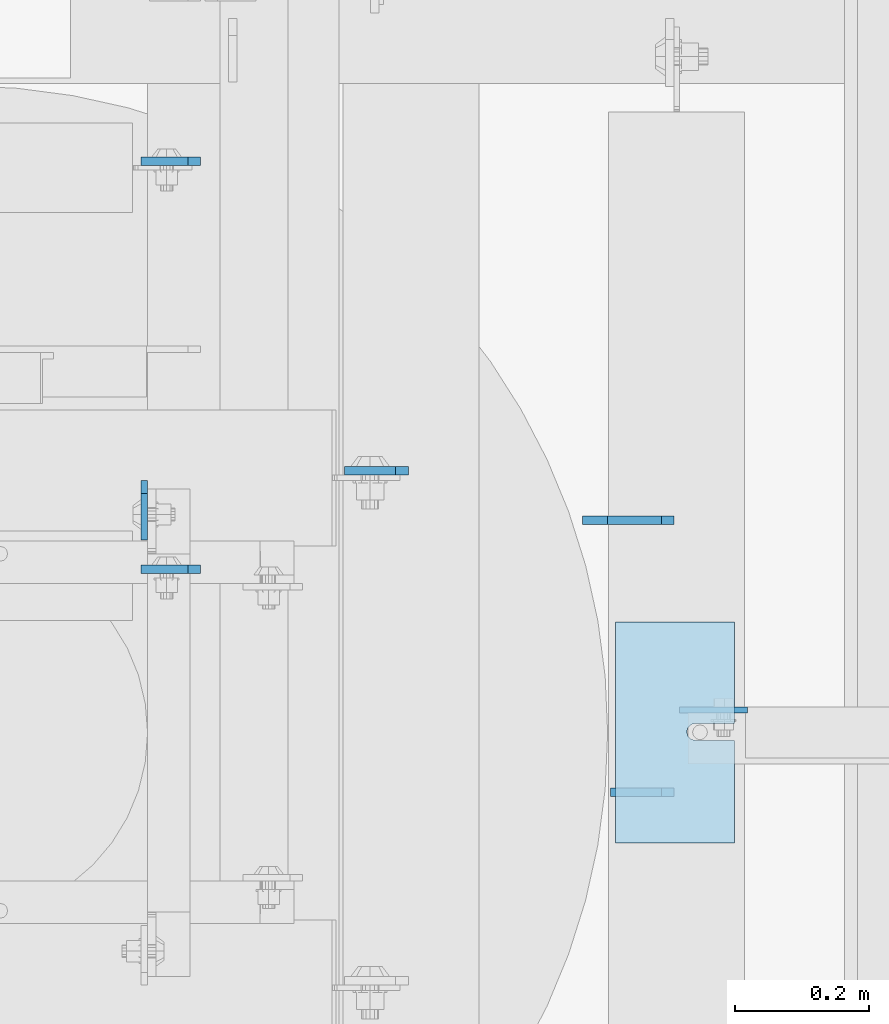
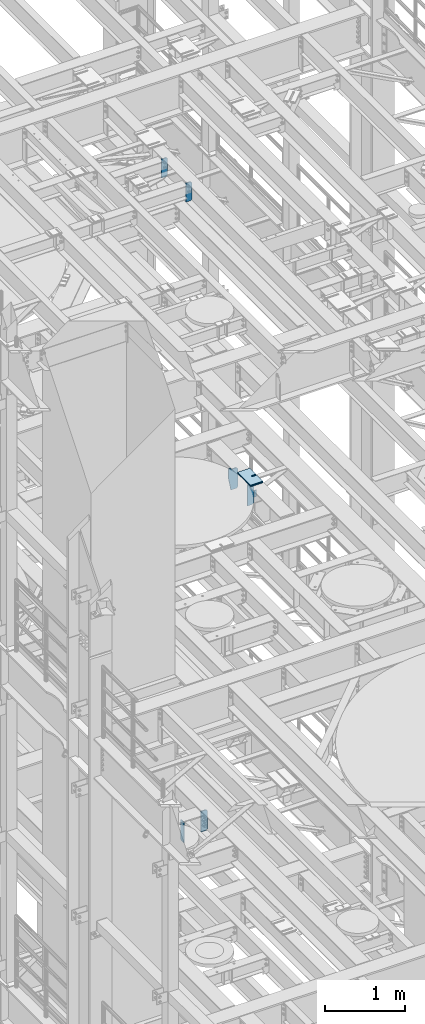
# One storey, part 1655 of 1876: 13 plates, 10 elements without a shape of their own.
"""IFC2X3 building model written with IfcOpenShell, lengths in millimetres."""

from ifc_helpers import new_model, si_unit, frame, origin_with_axes, place, context, subcontext, project, spatial, faceted_brep, material, type_object, element, aggregate, save


model = new_model("IFC2X3")

# Units and contexts
model_context = context("Model", 3, precision=1e-05, world=origin_with_axes())
body_context = subcontext(model_context, "Body", "Model", "MODEL_VIEW")
ifc_project = project(units=[si_unit("LENGTHUNIT", "METRE", prefix="MILLI"), si_unit("AREAUNIT", "SQUARE_METRE"), si_unit("VOLUMEUNIT", "CUBIC_METRE"), si_unit("MASSUNIT", "GRAM", prefix="KILO"), si_unit("TIMEUNIT", "SECOND"), si_unit("PLANEANGLEUNIT", "RADIAN"), si_unit("SOLIDANGLEUNIT", "STERADIAN"), si_unit("THERMODYNAMICTEMPERATUREUNIT", "DEGREE_CELSIUS"), si_unit("LUMINOUSINTENSITYUNIT", "LUMEN")], contexts=[model_context])

# Site, building, storey
site_placement = place(None, origin_with_axes())
site = spatial("IfcSite", under=ifc_project, at=site_placement, CompositionType="ELEMENT")
building_placement = place(site_placement, origin_with_axes())
building = spatial("IfcBuilding", under=site, at=building_placement, Name="Undefined", CompositionType="ELEMENT")
storey_placement = place(building_placement, origin_with_axes())
storey = spatial("IfcBuildingStorey", under=building, at=storey_placement, Name="Undefined", CompositionType="ELEMENT", Elevation=0.0)

# Assembly, plate
assembly_1_placement = place(storey_placement, origin_with_axes())
assembly_1 = element("IfcElementAssembly", 1, at=assembly_1_placement, inside=storey, Name="BEAM", AssemblyPlace="NOTDEFINED", PredefinedType="RIGID_FRAME")
ifc_material = material(Name="STEEL/A36")
plate_type_1 = type_object("IfcPlateType", PredefinedType="NOTDEFINED")
plate_1_placement = place(assembly_1_placement, frame((3646.48700008392, 5552.28125, 7821.6125), z_axis=(0.0, 0.0, 1.0), x_axis=(0.0, -1.0, 0.0)))
plate_1 = element("IfcPlate", 2, at=plate_1_placement, type_object=plate_type_1, material=ifc_material, Name="PLATE", context=body_context, shape_type="Brep", body=[
    faceted_brep([(0.0, -4.76249999999982, 19.0499992370605), (-1.81898940354586e-12, -4.76250000000073, 296.862499237061), (0.0, 4.76249999999982, 296.862499237061), (0.0, 4.76249999999982, 19.0499992370605), (19.0499992370605, -4.76249999999982, 315.912506103516), (19.0499992370605, 4.76249999999982, 315.912506103516), (88.9000015258789, -4.76249999999982, 315.912506103516), (88.9000015258789, 4.76249999999982, 315.912506103516), (88.9000015258789, -4.76249999999982, 0.0), (88.9000015258789, 4.76249999999982, 0.0), (19.0499992370605, -4.76249999999982, 0.0), (19.0499992370605, 4.76249999999982, 0.0)], [[[0, 1, 2, 3]], [[1, 4, 5, 2]], [[4, 6, 7, 5]], [[6, 8, 9, 7]], [[8, 10, 11, 9]], [[10, 0, 3, 11]], [[5, 7, 9, 11, 3, 2]], [[10, 8, 6, 4, 1, 0]]]),
])
aggregate(assembly_1, [plate_1])

assembly_2_placement = place(storey_placement, origin_with_axes())
assembly_2 = element("IfcElementAssembly", 3, at=assembly_2_placement, inside=storey, Name="BEAM", AssemblyPlace="NOTDEFINED", PredefinedType="RIGID_FRAME")
plate_type_2 = type_object("IfcPlateType", PredefinedType="NOTDEFINED")
plate_2_placement = place(assembly_2_placement, frame((4445.79374954281, 5209.42434844971, 13076.697618103), z_axis=(1.0, 0.0, 0.0), x_axis=(0.0, 0.0, -1.0)))
plate_2 = element("IfcPlate", 4, at=plate_2_placement, type_object=plate_type_2, material=ifc_material, Name="PLATE", context=body_context, shape_type="Brep", body=[
    faceted_brep([(0.0, -4.76249999999982, 0.0), (0.0, -4.76249999999982, 101.521789550781), (0.0, 4.76249999999982, 101.521789550781), (0.0, 4.76249999999982, 0.0), (100.472618103027, -4.76249999999982, 101.521789550781), (100.472618103027, 4.76249999999982, 101.521789550781), (100.472618103027, -4.76249999999982, 25.3999996185303), (100.472618103027, 4.76249999999982, 25.3999996185303), (75.0726184844971, -4.76249999999982, 0.0), (75.0726184844971, 4.76249999999982, 0.0)], [[[0, 1, 2, 3]], [[1, 4, 5, 2]], [[4, 6, 7, 5]], [[6, 8, 9, 7]], [[8, 0, 3, 9]], [[5, 7, 9, 3, 2]], [[8, 6, 4, 1, 0]]]),
])

# Assembly, plates
assembly_3_placement = place(storey_placement, origin_with_axes())
assembly_3 = element("IfcElementAssembly", 5, at=assembly_3_placement, inside=storey, Name="BEAM", AssemblyPlace="NOTDEFINED", PredefinedType="RIGID_FRAME")
plate_type_3 = type_object("IfcPlateType", PredefinedType="NOTDEFINED")
plate_3_placement = place(assembly_3_placement, frame((3730.625, 6029.09856576919, 17683.1625), z_axis=(0.0, 0.0, 1.0), x_axis=(-1.0, 0.0, 0.0)))
plate_3 = element("IfcPlate", 6, at=plate_3_placement, type_object=plate_type_3, material=ifc_material, Name="PLATE", context=body_context, shape_type="Brep", body=[
    faceted_brep([(0.0, -6.35000000000196, 19.0499992370605), (0.0, -6.35000000000036, 271.462512969971), (0.0, 6.35000000000036, 271.462512969971), (0.0, 6.35000000000105, 19.0499992370605), (19.0499992370605, -6.35000000000036, 290.512512207031), (19.0499992370605, 6.35000000000036, 290.512512207031), (88.9000015258789, -6.35000000000036, 290.512512207031), (88.9000015258789, 6.35000000000036, 290.512512207031), (88.9000015258789, -6.34999999999991, 0.0), (88.9000015258789, 6.34999999999991, 0.0), (19.0499992370642, -6.35000000000105, 0.0), (19.0499992370633, 6.35000000000105, 0.0)], [[[0, 1, 2, 3]], [[1, 4, 5, 2]], [[4, 6, 7, 5]], [[6, 8, 9, 7]], [[8, 10, 11, 9]], [[10, 0, 3, 11]], [[5, 7, 9, 11, 3, 2]], [[10, 8, 6, 4, 1, 0]]]),
])
plate_4_placement = place(assembly_3_placement, frame((3730.625, 5419.49856576919, 17683.1625), z_axis=(0.0, 0.0, 1.0), x_axis=(-1.0, 0.0, 0.0)))
plate_4 = element("IfcPlate", 7, at=plate_4_placement, type_object=plate_type_3, material=ifc_material, Name="PLATE", context=body_context, shape_type="Brep", body=[
    faceted_brep([(0.0, -6.35000000000196, 19.0499992370605), (0.0, -6.35000000000036, 271.462512969971), (0.0, 6.35000000000036, 271.462512969971), (0.0, 6.35000000000105, 19.0499992370605), (19.0499992370605, -6.35000000000036, 290.512512207031), (19.0499992370605, 6.35000000000036, 290.512512207031), (88.9000015258789, -6.35000000000036, 290.512512207031), (88.9000015258789, 6.35000000000036, 290.512512207031), (88.9000015258789, -6.34999999999991, 0.0), (88.9000015258789, 6.34999999999991, 0.0), (19.0499992370642, -6.35000000000105, 0.0), (19.0499992370633, 6.35000000000105, 0.0)], [[[0, 1, 2, 3]], [[1, 4, 5, 2]], [[4, 6, 7, 5]], [[6, 8, 9, 7]], [[8, 10, 11, 9]], [[10, 0, 3, 11]], [[5, 7, 9, 11, 3, 2]], [[10, 8, 6, 4, 1, 0]]]),
])
aggregate(assembly_3, [plate_3, plate_4])

# Plate
plate_type_4 = type_object("IfcPlateType", PredefinedType="NOTDEFINED")
plate_5_placement = place(assembly_2_placement, frame((4437.85625, 5086.3499993653, 12976.225), z_axis=(0.0, 0.0, 1.0), x_axis=(-1.0, 0.0, 0.0)))
plate_5 = element("IfcPlate", 8, at=plate_5_placement, type_object=plate_type_4, material=ifc_material, Name="PLATE", context=body_context, shape_type="Brep", body=[
    faceted_brep([(0.0, -6.35000000000196, 19.0499992370605), (0.0, -6.35000000000196, 298.450000762939), (0.0, 6.35000000000105, 298.450000762939), (0.0, 6.35000000000105, 19.0499992370605), (19.0499992370642, -6.35000000000105, 317.5), (19.0499992370633, 6.35000000000105, 317.5), (95.25, -6.35000000000036, 317.5), (95.25, 6.35000000000036, 317.5), (95.25, -6.35000000000036, 0.0), (95.25, 6.35000000000036, 0.0), (19.0499992370642, -6.35000000000105, 0.0), (19.0499992370633, 6.35000000000105, 0.0)], [[[0, 1, 2, 3]], [[1, 4, 5, 2]], [[4, 6, 7, 5]], [[6, 8, 9, 7]], [[8, 10, 11, 9]], [[10, 0, 3, 11]], [[5, 7, 9, 11, 3, 2]], [[10, 8, 6, 4, 1, 0]]]),
])

# Assembly, plate
assembly_4_placement = place(storey_placement, origin_with_axes())
assembly_4 = element("IfcElementAssembly", 9, at=assembly_4_placement, inside=storey, Name="BEAM", AssemblyPlace="NOTDEFINED", PredefinedType="RIGID_FRAME")
plate_6_placement = place(assembly_4_placement, frame((4040.98087964162, 5566.56875009536, 7821.6125), z_axis=(0.0, 0.0, 1.0), x_axis=(-1.0, 0.0, 0.0)))
plate_6 = element("IfcPlate", 10, at=plate_6_placement, type_object=plate_type_4, material=ifc_material, Name="PLATE", context=body_context, shape_type="Brep", body=[
    faceted_brep([(0.0, -6.35000000000196, 19.0499992370605), (-9.09494701772928e-13, -6.34999999999764, 296.862506866455), (1.81898940354586e-12, 6.34999999999786, 296.862506866455), (0.0, 6.35000000000105, 19.0499992370605), (19.0499992370587, -6.34999999999604, 315.912506103516), (19.0499992370624, 6.34999999999945, 315.912506103516), (95.25, -6.35000000000036, 315.912506103516), (95.25, 6.35000000000036, 315.912506103516), (95.25, -6.35000000000036, 0.0), (95.25, 6.35000000000036, 0.0), (19.0499992370642, -6.35000000000105, 0.0), (19.0499992370633, 6.35000000000105, 0.0)], [[[0, 1, 2, 3]], [[1, 4, 5, 2]], [[4, 6, 7, 5]], [[6, 8, 9, 7]], [[8, 10, 11, 9]], [[10, 0, 3, 11]], [[5, 7, 9, 11, 3, 2]], [[10, 8, 6, 4, 1, 0]]]),
])
aggregate(assembly_4, [plate_6])

assembly_5_placement = place(storey_placement, origin_with_axes())
assembly_5 = element("IfcElementAssembly", 11, at=assembly_5_placement, inside=storey, Name="SHIM PLATE", AssemblyPlace="NOTDEFINED", PredefinedType="RIGID_FRAME")
plate_type_5 = type_object("IfcPlateType", PredefinedType="NOTDEFINED")
plate_7_placement = place(assembly_5_placement, frame((4350.69810638428, 5010.847364135, 13335.7925), z_axis=(0.0, 1.0, 0.0), x_axis=(1.0, 0.0, 0.0)))
plate_7 = element("IfcPlate", 12, at=plate_7_placement, type_object=plate_type_5, material=ifc_material, Name="SHIM PLATE", context=body_context, shape_type="Brep", body=[
    faceted_brep([(177.654449462891, -0.793499999999767, 153.152024232435), (177.654449462891, 0.793499999999767, 153.152024232435), (118.915740966797, 0.793499999999767, 153.152024232435), (118.915740966797, -0.793499999999767, 153.152024232435), (112.565739046814, 0.793499999999767, 154.853499989362), (112.565739046814, -0.793499999999767, 154.853499989362), (107.917214530273, 0.793499999999767, 159.502022760557), (107.917214530273, -0.793499999999767, 159.502022760557), (106.21573638916, 0.793499999999767, 165.8520240417), (106.21573638916, -0.793499999999767, 165.8520240417), (107.917214530273, 0.793499999999767, 172.202025322844), (107.917214530273, -0.793499999999767, 172.202025322844), (112.565739046813, 0.793499999999767, 176.850548094039), (112.565739046813, -0.793499999999767, 176.850548094039), (118.915740966797, 0.793499999999767, 178.552023850965), (118.915740966797, -0.793499999999767, 178.552023850965), (177.654449462891, -0.793499999999767, 178.552023850965), (177.654449462891, 0.793499999999767, 178.552023850965), (177.654449462891, -0.793499999999767, 0.0), (9.09494701772928e-13, -0.793499999999767, 0.0), (9.09494701772928e-13, 0.793499999999767, 0.0), (177.654449462891, 0.793499999999767, 0.0), (0.0, -0.793499999999767, 330.201965332031), (0.0, 0.793499999999767, 330.201965332031), (177.654449462891, -0.793499999999767, 330.201965332031), (177.654449462891, 0.793499999999767, 330.201965332031)], [[[0, 1, 2, 3]], [[3, 2, 4, 5]], [[5, 4, 6, 7]], [[7, 6, 8, 9]], [[9, 8, 10, 11]], [[11, 10, 12, 13]], [[13, 12, 14, 15]], [[16, 15, 14, 17]], [[18, 19, 20, 21]], [[19, 22, 23, 20]], [[22, 24, 25, 23]], [[25, 24, 16, 17]], [[12, 10, 8, 6, 4, 2, 1, 21, 20, 23, 25, 17, 14]], [[18, 21, 1, 0]], [[24, 22, 19, 18, 0, 3, 5, 7, 9, 11, 13, 15, 16]]]),
])
aggregate(assembly_5, [plate_7])

assembly_6_placement = place(storey_placement, origin_with_axes())
assembly_6 = element("IfcElementAssembly", 13, at=assembly_6_placement, inside=storey, Name="SHIM PLATE", AssemblyPlace="NOTDEFINED", PredefinedType="RIGID_FRAME")
plate_type_6 = type_object("IfcPlateType", PredefinedType="NOTDEFINED")
plate_8_placement = place(assembly_6_placement, frame((4350.69810638428, 5010.847364135, 13333.4115), z_axis=(0.0, 1.0, 0.0), x_axis=(1.0, 0.0, 0.0)))
plate_8 = element("IfcPlate", 14, at=plate_8_placement, type_object=plate_type_6, material=ifc_material, Name="SHIM PLATE", context=body_context, shape_type="Brep", body=[
    faceted_brep([(177.654449462891, -1.58749999999964, 153.152024232435), (177.654449462891, 1.58749999999964, 153.152024232435), (118.915740966797, 1.58749999999964, 153.152024232435), (118.915740966797, -1.58749999999964, 153.152024232435), (112.565739046814, 1.58749999999964, 154.853499989362), (112.565739046814, -1.58749999999964, 154.853499989362), (107.917214530273, 1.58749999999964, 159.502022760557), (107.917214530273, -1.58749999999964, 159.502022760557), (106.21573638916, 1.58749999999964, 165.8520240417), (106.21573638916, -1.58749999999964, 165.8520240417), (107.917214530273, 1.58749999999964, 172.202025322844), (107.917214530273, -1.58749999999964, 172.202025322844), (112.565739046813, 1.58749999999964, 176.850548094039), (112.565739046813, -1.58749999999964, 176.850548094039), (118.915740966797, 1.58749999999964, 178.552023850965), (118.915740966797, -1.58749999999964, 178.552023850965), (177.654449462891, -1.58749999999964, 178.552023850965), (177.654449462891, 1.58749999999964, 178.552023850965), (177.654449462891, -1.58749999999964, 0.0), (9.09494701772928e-13, -1.58750000000146, 4.54747350886464e-13), (9.09494701772928e-13, 1.58750000000146, 4.54747350886464e-13), (177.654449462891, 1.58749999999964, 0.0), (0.0, -1.58749999999964, 330.201965332031), (0.0, 1.58749999999964, 330.201965332031), (177.654449462891, -1.58749999999964, 330.201965332031), (177.654449462891, 1.58749999999964, 330.201965332031)], [[[0, 1, 2, 3]], [[3, 2, 4, 5]], [[5, 4, 6, 7]], [[7, 6, 8, 9]], [[9, 8, 10, 11]], [[11, 10, 12, 13]], [[13, 12, 14, 15]], [[16, 15, 14, 17]], [[18, 19, 20, 21]], [[19, 22, 23, 20]], [[22, 24, 25, 23]], [[25, 24, 16, 17]], [[12, 10, 8, 6, 4, 2, 1, 21, 20, 23, 25, 17, 14]], [[18, 21, 1, 0]], [[24, 22, 19, 18, 0, 3, 5, 7, 9, 11, 13, 15, 16]]]),
])
aggregate(assembly_6, [plate_8])

assembly_7_placement = place(storey_placement, origin_with_axes())
assembly_7 = element("IfcElementAssembly", 15, at=assembly_7_placement, inside=storey, Name="SHIM PLATE", AssemblyPlace="NOTDEFINED", PredefinedType="RIGID_FRAME")
plate_9_placement = place(assembly_7_placement, frame((4350.69810638428, 5010.847364135, 13330.2365), z_axis=(0.0, 1.0, 0.0), x_axis=(1.0, 0.0, 0.0)))
plate_9 = element("IfcPlate", 16, at=plate_9_placement, type_object=plate_type_6, material=ifc_material, Name="SHIM PLATE", context=body_context, shape_type="Brep", body=[
    faceted_brep([(177.654449462891, -1.58749999999964, 153.152024232435), (177.654449462891, 1.58749999999964, 153.152024232435), (118.915740966797, 1.58749999999964, 153.152024232435), (118.915740966797, -1.58749999999964, 153.152024232435), (112.565739046814, 1.58749999999964, 154.853499989362), (112.565739046814, -1.58749999999964, 154.853499989362), (107.917214530273, 1.58749999999964, 159.502022760557), (107.917214530273, -1.58749999999964, 159.502022760557), (106.21573638916, 1.58749999999964, 165.8520240417), (106.21573638916, -1.58749999999964, 165.8520240417), (107.917214530273, 1.58749999999964, 172.202025322844), (107.917214530273, -1.58749999999964, 172.202025322844), (112.565739046813, 1.58749999999964, 176.850548094039), (112.565739046813, -1.58749999999964, 176.850548094039), (118.915740966797, 1.58749999999964, 178.552023850965), (118.915740966797, -1.58749999999964, 178.552023850965), (177.654449462891, -1.58749999999964, 178.552023850965), (177.654449462891, 1.58749999999964, 178.552023850965), (177.654449462891, -1.58749999999964, 0.0), (9.09494701772928e-13, -1.58750000000146, 4.54747350886464e-13), (9.09494701772928e-13, 1.58750000000146, 4.54747350886464e-13), (177.654449462891, 1.58749999999964, 0.0), (0.0, -1.58749999999964, 330.201965332031), (0.0, 1.58749999999964, 330.201965332031), (177.654449462891, -1.58749999999964, 330.201965332031), (177.654449462891, 1.58749999999964, 330.201965332031)], [[[0, 1, 2, 3]], [[3, 2, 4, 5]], [[5, 4, 6, 7]], [[7, 6, 8, 9]], [[9, 8, 10, 11]], [[11, 10, 12, 13]], [[13, 12, 14, 15]], [[16, 15, 14, 17]], [[18, 19, 20, 21]], [[19, 22, 23, 20]], [[22, 24, 25, 23]], [[25, 24, 16, 17]], [[12, 10, 8, 6, 4, 2, 1, 21, 20, 23, 25, 17, 14]], [[18, 21, 1, 0]], [[24, 22, 19, 18, 0, 3, 5, 7, 9, 11, 13, 15, 16]]]),
])
aggregate(assembly_7, [plate_9])

assembly_8_placement = place(storey_placement, origin_with_axes())
assembly_8 = element("IfcElementAssembly", 17, at=assembly_8_placement, inside=storey, Name="SHIM PLATE", AssemblyPlace="NOTDEFINED", PredefinedType="RIGID_FRAME")
plate_type_7 = type_object("IfcPlateType", PredefinedType="NOTDEFINED")
plate_10_placement = place(assembly_8_placement, frame((4350.69810638428, 5010.847364135, 13326.268), z_axis=(0.0, 1.0, 0.0), x_axis=(1.0, 0.0, 0.0)))
plate_10 = element("IfcPlate", 18, at=plate_10_placement, type_object=plate_type_7, material=ifc_material, Name="SHIM PLATE", context=body_context, shape_type="Brep", body=[
    faceted_brep([(177.654449462891, -2.3809999999994, 153.152024232435), (177.654449462891, 2.3809999999994, 153.152024232435), (118.915740966797, 2.3809999999994, 153.152024232435), (118.915740966797, -2.3809999999994, 153.152024232435), (112.565739046814, 2.3809999999994, 154.853499989362), (112.565739046814, -2.3809999999994, 154.853499989362), (107.917214530273, 2.3809999999994, 159.502022760557), (107.917214530273, -2.3809999999994, 159.502022760557), (106.21573638916, 2.3809999999994, 165.8520240417), (106.21573638916, -2.3809999999994, 165.8520240417), (107.917214530273, 2.3809999999994, 172.202025322844), (107.917214530273, -2.3809999999994, 172.202025322844), (112.565739046813, 2.3809999999994, 176.850548094039), (112.565739046813, -2.3809999999994, 176.850548094039), (118.915740966797, 2.3809999999994, 178.552023850965), (118.915740966797, -2.3809999999994, 178.552023850965), (177.654449462891, -2.3809999999994, 178.552023850965), (177.654449462891, 2.3809999999994, 178.552023850965), (177.654449462891, -2.3809999999994, 0.0), (0.0, -2.38100000000122, 4.54747350886464e-13), (0.0, 2.38100000000122, 4.54747350886464e-13), (177.654449462891, 2.3809999999994, 0.0), (0.0, -2.3809999999994, 330.201965332031), (0.0, 2.3809999999994, 330.201965332031), (177.654449462891, -2.3809999999994, 330.201965332031), (177.654449462891, 2.3809999999994, 330.201965332031)], [[[0, 1, 2, 3]], [[3, 2, 4, 5]], [[5, 4, 6, 7]], [[7, 6, 8, 9]], [[9, 8, 10, 11]], [[11, 10, 12, 13]], [[13, 12, 14, 15]], [[16, 15, 14, 17]], [[18, 19, 20, 21]], [[19, 22, 23, 20]], [[22, 24, 25, 23]], [[25, 24, 16, 17]], [[12, 10, 8, 6, 4, 2, 1, 21, 20, 23, 25, 17, 14]], [[18, 21, 1, 0]], [[24, 22, 19, 18, 0, 3, 5, 7, 9, 11, 13, 15, 16]]]),
])
aggregate(assembly_8, [plate_10])

assembly_9_placement = place(storey_placement, origin_with_axes())
assembly_9 = element("IfcElementAssembly", 19, at=assembly_9_placement, inside=storey, Name="SHIM PLATE", AssemblyPlace="NOTDEFINED", PredefinedType="RIGID_FRAME")
plate_11_placement = place(assembly_9_placement, frame((4350.69810638428, 5010.847364135, 13321.506), z_axis=(0.0, 1.0, 0.0), x_axis=(1.0, 0.0, 0.0)))
plate_11 = element("IfcPlate", 20, at=plate_11_placement, type_object=plate_type_7, material=ifc_material, Name="SHIM PLATE", context=body_context, shape_type="Brep", body=[
    faceted_brep([(177.654449462891, -2.3809999999994, 153.152024232435), (177.654449462891, 2.3809999999994, 153.152024232435), (118.915740966797, 2.3809999999994, 153.152024232435), (118.915740966797, -2.3809999999994, 153.152024232435), (112.565739046814, 2.3809999999994, 154.853499989362), (112.565739046814, -2.3809999999994, 154.853499989362), (107.917214530273, 2.3809999999994, 159.502022760557), (107.917214530273, -2.3809999999994, 159.502022760557), (106.21573638916, 2.3809999999994, 165.8520240417), (106.21573638916, -2.3809999999994, 165.8520240417), (107.917214530273, 2.3809999999994, 172.202025322844), (107.917214530273, -2.3809999999994, 172.202025322844), (112.565739046813, 2.3809999999994, 176.850548094039), (112.565739046813, -2.3809999999994, 176.850548094039), (118.915740966797, 2.3809999999994, 178.552023850965), (118.915740966797, -2.3809999999994, 178.552023850965), (177.654449462891, -2.3809999999994, 178.552023850965), (177.654449462891, 2.3809999999994, 178.552023850965), (177.654449462891, -2.3809999999994, 0.0), (0.0, -2.38100000000122, 4.54747350886464e-13), (0.0, 2.38100000000122, 4.54747350886464e-13), (177.654449462891, 2.3809999999994, 0.0), (0.0, -2.3809999999994, 330.201965332031), (0.0, 2.3809999999994, 330.201965332031), (177.654449462891, -2.3809999999994, 330.201965332031), (177.654449462891, 2.3809999999994, 330.201965332031)], [[[0, 1, 2, 3]], [[3, 2, 4, 5]], [[5, 4, 6, 7]], [[7, 6, 8, 9]], [[9, 8, 10, 11]], [[11, 10, 12, 13]], [[13, 12, 14, 15]], [[16, 15, 14, 17]], [[18, 19, 20, 21]], [[19, 22, 23, 20]], [[22, 24, 25, 23]], [[25, 24, 16, 17]], [[12, 10, 8, 6, 4, 2, 1, 21, 20, 23, 25, 17, 14]], [[18, 21, 1, 0]], [[24, 22, 19, 18, 0, 3, 5, 7, 9, 11, 13, 15, 16]]]),
])
aggregate(assembly_9, [plate_11])

assembly_10_placement = place(storey_placement, origin_with_axes())
assembly_10 = element("IfcElementAssembly", 21, at=assembly_10_placement, inside=storey, Name="SHIM PLATE", AssemblyPlace="NOTDEFINED", PredefinedType="RIGID_FRAME")
plate_type_8 = type_object("IfcPlateType", PredefinedType="NOTDEFINED")
plate_12_placement = place(assembly_10_placement, frame((4350.69810638428, 5010.847364135, 13314.3625), z_axis=(0.0, 1.0, 0.0), x_axis=(1.0, 0.0, 0.0)))
plate_12 = element("IfcPlate", 22, at=plate_12_placement, type_object=plate_type_8, material=ifc_material, Name="SHIM PLATE", context=body_context, shape_type="Brep", body=[
    faceted_brep([(177.654449462891, -4.76250000000073, 153.152024232435), (177.654449462891, 4.76250000000073, 153.152024232435), (118.915740966797, 4.76250000000073, 153.152024232435), (118.915740966797, -4.76250000000073, 153.152024232435), (112.565739046814, 4.76250000000073, 154.853499989362), (112.565739046814, -4.76250000000073, 154.853499989362), (107.917214530273, 4.76250000000073, 159.502022760557), (107.917214530273, -4.76250000000073, 159.502022760557), (106.21573638916, 4.76250000000073, 165.8520240417), (106.21573638916, -4.76250000000073, 165.8520240417), (107.917214530273, 4.76250000000073, 172.202025322844), (107.917214530273, -4.76250000000073, 172.202025322844), (112.565739046813, 4.76250000000073, 176.850548094039), (112.565739046813, -4.76250000000073, 176.850548094039), (118.915740966797, 4.76250000000073, 178.552023850965), (118.915740966797, -4.76250000000073, 178.552023850965), (177.654449462891, -4.76250000000073, 178.552023850965), (177.654449462891, 4.76250000000073, 178.552023850965), (177.654449462891, -4.76250000000073, 0.0), (0.0, -4.76249999999982, 0.0), (0.0, 4.76249999999982, 0.0), (177.654449462891, 4.76250000000073, 0.0), (0.0, -4.76250000000073, 330.201965332031), (0.0, 4.76250000000073, 330.201965332031), (177.654449462891, -4.76250000000073, 330.201965332031), (177.654449462891, 4.76250000000073, 330.201965332031)], [[[0, 1, 2, 3]], [[3, 2, 4, 5]], [[5, 4, 6, 7]], [[7, 6, 8, 9]], [[9, 8, 10, 11]], [[11, 10, 12, 13]], [[13, 12, 14, 15]], [[16, 15, 14, 17]], [[18, 19, 20, 21]], [[19, 22, 23, 20]], [[22, 24, 25, 23]], [[25, 24, 16, 17]], [[12, 10, 8, 6, 4, 2, 1, 21, 20, 23, 25, 17, 14]], [[18, 21, 1, 0]], [[24, 22, 19, 18, 0, 3, 5, 7, 9, 11, 13, 15, 16]]]),
])
aggregate(assembly_10, [plate_12])

# Plate
plate_type_9 = type_object("IfcPlateType", PredefinedType="NOTDEFINED")
plate_13_placement = place(assembly_2_placement, frame((4340.22500133054, 5492.7499993653, 12976.2250305176), z_axis=(0.0, 0.0, 1.0), x_axis=(1.0, 0.0, 0.0)))
plate_13 = element("IfcPlate", 23, at=plate_13_placement, type_object=plate_type_9, material=ifc_material, Name="PLATE", context=body_context, shape_type="Brep", body=[
    faceted_brep([(0.0, -6.35000000000036, 0.0), (-38.8939666748338, -6.34999999991305, 206.374969482462), (-38.8939666748338, 6.35000000008768, 206.374969482466), (0.0, 6.35000000000036, 0.0), (-38.8940048218228, -6.34999999985848, 333.374969482467), (-38.8940048218228, 6.35000000014224, 333.374969482475), (-1.58718562130525, -6.34999999985121, 333.374969482444), (-1.58718562130525, 6.35000000014861, 333.374969482438), (-1.58756351473312, -6.35000000001992, 317.499969482458), (-1.58756351473858, 6.34999999998013, 317.499969482449), (78.5811500548944, -6.34999999985939, 317.499994140582), (78.5811500548944, 6.35000000014134, 317.499994140577), (97.6311552428851, -6.34999999986758, 298.450000762883), (97.6311552428851, 6.35000000013315, 298.450000762878), (97.6312425231954, -6.34999999999218, 19.049999237006), (97.6312425231954, 6.35000000000855, 19.0499992370005), (78.5812492370633, -6.35000000000036, -4.18367562815547e-11), (78.5812492370633, 6.35000000000036, -4.72937244921923e-11)], [[[0, 1, 2, 3]], [[1, 4, 5, 2]], [[4, 6, 7, 5]], [[6, 8, 9, 7]], [[8, 10, 11, 9]], [[10, 12, 13, 11]], [[12, 14, 15, 13]], [[14, 16, 17, 15]], [[16, 0, 3, 17]], [[5, 7, 9, 11, 13, 15, 17, 3, 2]], [[16, 14, 12, 10, 8, 6, 4, 1, 0]]]),
])

aggregate(assembly_2, [plate_2, plate_5, plate_13])

save(model, "model.ifc")
